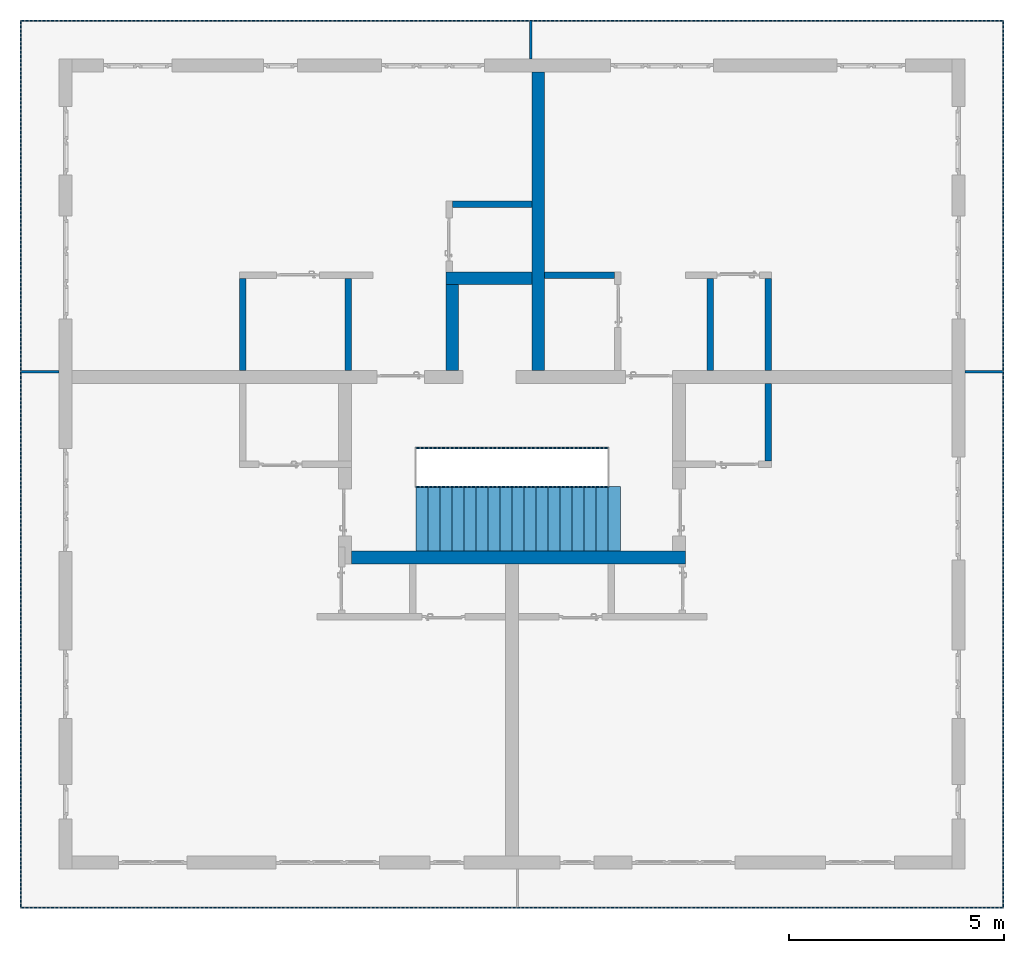
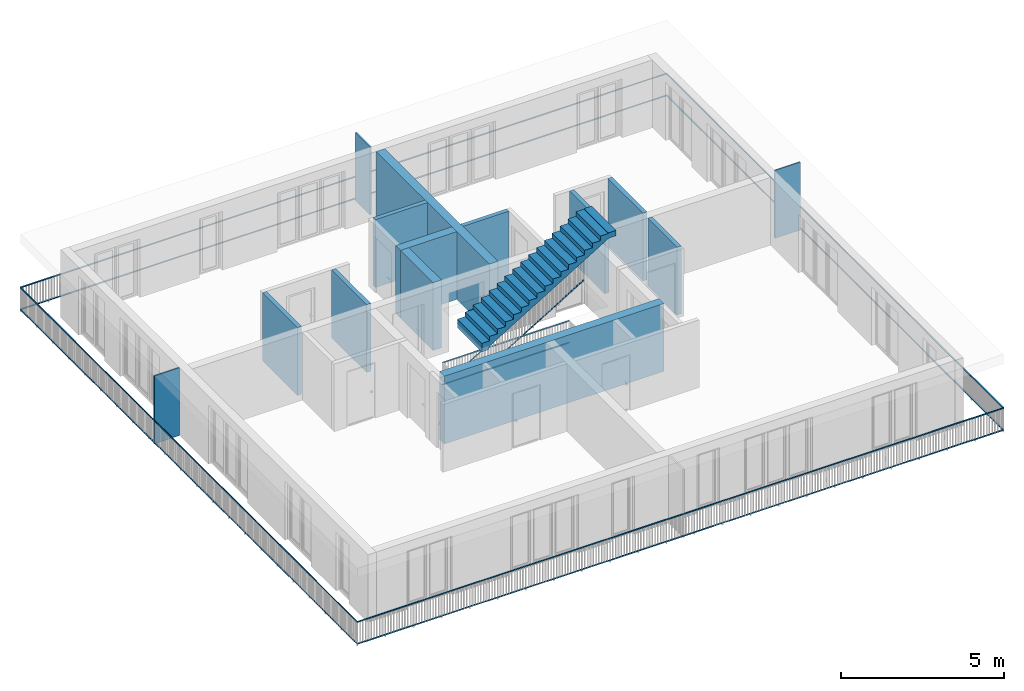
# One storey, part 24 of 48: 14 walls, 13 building element parts, 4 elements without a shape of their own.
"""IFC4 building model written with IfcOpenShell, lengths in metres."""

from ifc_helpers import new_model, entity, si_unit, converted_unit, derived_unit, direction, frame, origin_with_axes, place, context, subcontext, project, spatial, polygons, material, type_object, element, aggregate, save


model = new_model("IFC4")

# Units and contexts
model_context = context("Model", 3, precision=1e-05, world=origin_with_axes(), true_north=direction((0.0, 1.0)))
body_context = subcontext(model_context, "Body", "Model", "MODEL_VIEW")
ifc_project = project(units=[si_unit("LENGTHUNIT", "METRE"), si_unit("AREAUNIT", "SQUARE_METRE"), si_unit("VOLUMEUNIT", "CUBIC_METRE"), converted_unit("PLANEANGLEUNIT", "DEGREE", entity("IfcPlaneAngleMeasure", 0.0174532925199), si_unit("PLANEANGLEUNIT", "RADIAN"), dimensions=[0, 0, 0, 0, 0, 0, 0]), converted_unit("TIMEUNIT", "Year", entity("IfcTimeMeasure", 31556926.0), si_unit("TIMEUNIT", "SECOND"), dimensions=[0, 0, 1, 0, 0, 0, 0]), si_unit("MASSUNIT", "GRAM", prefix="KILO"), si_unit("THERMODYNAMICTEMPERATUREUNIT", "DEGREE_CELSIUS"), si_unit("LUMINOUSINTENSITYUNIT", "LUMEN"), si_unit("ENERGYUNIT", "JOULE", prefix="MEGA"), derived_unit("THERMALCONDUCTANCEUNIT", [(si_unit("POWERUNIT", "WATT"), 1), (si_unit("LENGTHUNIT", "METRE"), -1), (si_unit("THERMODYNAMICTEMPERATUREUNIT", "KELVIN"), -1)]), derived_unit("SPECIFICHEATCAPACITYUNIT", [(si_unit("ENERGYUNIT", "JOULE"), 1), (si_unit("MASSUNIT", "GRAM", prefix="KILO"), -1), (si_unit("THERMODYNAMICTEMPERATUREUNIT", "KELVIN"), -1)]), derived_unit("MASSDENSITYUNIT", [(si_unit("MASSUNIT", "GRAM", prefix="KILO"), 1), (si_unit("VOLUMEUNIT", "CUBIC_METRE"), -1)])], contexts=[model_context])

# Site, building, storey
site_placement = place(None, origin_with_axes())
site = spatial("IfcSite", under=ifc_project, at=site_placement, CompositionType="ELEMENT")
building_placement = place(site_placement, origin_with_axes())
building = spatial("IfcBuilding", under=site, at=building_placement, CompositionType="ELEMENT")
storey_placement = place(building_placement, frame((0.0, 0.0, 3.4), z_axis=(0.0, 0.0, 1.0), x_axis=(1.0, 0.0, 0.0)))
storey = spatial("IfcBuildingStorey", under=building, at=storey_placement, Name="1. Geschoss", CompositionType="ELEMENT", Elevation=3.4)

# Walls
ifc_material_1 = material()
wall_type_1 = type_object("IfcWallType", Name="300", PredefinedType="NOTDEFINED")
wall_1_placement = place(storey_placement, frame((2.8378006196, -2.52881223104, 0.0), z_axis=(0.0, 0.0, 1.0), x_axis=(-1.0, 0.0, 0.0)))
element("IfcWall", 1, at=wall_1_placement, inside=storey, type_object=wall_type_1, material=ifc_material_1, Name="Wand-001", PredefinedType="NOTDEFINED", context=body_context, shape_type="Tessellation", body=[
    polygons([(7.78, 0.0, 2.54), (6.28, 0.0, 2.54), (1.8, 0.0, 2.54), (0.0, 0.0, 2.54), (0.0, 0.0, 0.0), (7.78, 0.0, 0.0), (7.78, 0.3, 2.54), (0.0, 0.3, 2.54), (0.0, 0.3, 0.0), (7.78, 0.3, 0.0)], [[[1, 2, 3, 4, 5, 6]], [[4, 3, 2, 1, 7, 8]], [[5, 4, 8, 9]], [[5, 9, 10, 6]], [[10, 7, 1, 6]], [[8, 7, 10, 9]]], closed=True),
])
wall_2_placement = place(storey_placement, frame((-2.7421993804, 3.67118776896, 0.0), z_axis=(0.0, 0.0, 1.0), x_axis=(1.0, 0.0, 0.0)))
element("IfcWall", 2, at=wall_2_placement, inside=storey, type_object=wall_type_1, material=ifc_material_1, Name="Wand-001", PredefinedType="NOTDEFINED", context=body_context, shape_type="Tessellation", body=[
    polygons([(0.0, 0.3, 0.0), (0.0, 0.3, 2.54), (2.0, 0.3, 2.54), (2.0, 0.3, 0.0), (0.0, 0.0, 0.0), (0.0, 0.0, 2.54), (2.0, 0.0, 2.54), (2.0, 0.0, 0.0)], [[[1, 2, 3, 4]], [[5, 6, 2, 1]], [[6, 7, 3, 2]], [[4, 3, 7, 8]], [[5, 1, 4, 8]], [[8, 7, 6, 5]]], closed=True),
])
wall_3_placement = place(storey_placement, frame((-2.7421993804, 1.37118776896, 0.0), z_axis=(0.0, 0.0, 1.0), x_axis=(0.0, 1.0, 0.0)))
element("IfcWall", 3, at=wall_3_placement, inside=storey, type_object=wall_type_1, material=ifc_material_1, Name="Wand-001", PredefinedType="NOTDEFINED", context=body_context, shape_type="Tessellation", body=[
    polygons([(2.3, 0.0, 0.0), (2.3, 0.0, 2.54), (2.3, -0.3, 2.54), (2.3, -0.3, 0.0), (0.3, 0.0, 0.0), (0.3, 0.0, 2.54), (0.3, -0.3, 2.54), (0.3, -0.3, 0.0)], [[[1, 2, 3, 4]], [[5, 6, 2, 1]], [[6, 7, 3, 2]], [[4, 3, 7, 8]], [[5, 1, 4, 8]], [[8, 7, 6, 5]]], closed=True),
])
wall_4_placement = place(storey_placement, frame((-0.742199380397, 1.37118776896, 0.0), z_axis=(0.0, 0.0, 1.0), x_axis=(0.0, 1.0, 0.0)))
element("IfcWall", 4, at=wall_4_placement, inside=storey, type_object=wall_type_1, material=ifc_material_1, Name="Wand-001", PredefinedType="NOTDEFINED", context=body_context, shape_type="Tessellation", body=[
    polygons([(7.25, 0.0, 0.0), (7.25, 0.0, 2.54), (7.25, -0.3, 2.54), (7.25, -0.3, 0.0), (0.3, 0.0, 0.0), (0.3, 0.0, 2.54), (0.3, -0.3, 2.54), (0.3, -0.3, 0.0)], [[[1, 2, 3, 4]], [[5, 6, 2, 1]], [[6, 7, 3, 2]], [[4, 3, 7, 8]], [[8, 5, 1, 4]], [[8, 7, 6, 5]]], closed=True),
])
wall_type_2 = type_object("IfcWallType", Name="150", PredefinedType="NOTDEFINED")
wall_5_placement = place(storey_placement, frame((3.3378006196, 1.37118776896, 0.0), z_axis=(0.0, 0.0, 1.0), x_axis=(0.0, 1.0, 0.0)))
element("IfcWall", 5, at=wall_5_placement, inside=storey, type_object=wall_type_2, material=ifc_material_1, Name="Wand-002", PredefinedType="NOTDEFINED", context=body_context, shape_type="Tessellation", body=[
    polygons([(2.45, 0.0, 0.0), (2.45, 0.0, 2.54), (2.45, -0.15, 2.54), (2.45, -0.15, 0.0), (0.3, 0.0, 0.0), (0.3, 0.0, 2.54), (0.3, -0.15, 2.54), (0.3, -0.15, 0.0)], [[[1, 2, 3, 4]], [[5, 6, 2, 1]], [[6, 7, 3, 2]], [[4, 3, 7, 8]], [[5, 1, 4, 8]], [[8, 7, 6, 5]]], closed=True),
])
wall_6_placement = place(storey_placement, frame((-4.9421993804, 1.37118776896, 0.0), z_axis=(0.0, 0.0, 1.0), x_axis=(0.0, 1.0, 0.0)))
element("IfcWall", 6, at=wall_6_placement, inside=storey, type_object=wall_type_2, material=ifc_material_1, Name="Wand-002", PredefinedType="NOTDEFINED", context=body_context, shape_type="Tessellation", body=[
    polygons([(2.45, 0.15, 0.0), (2.45, 0.15, 2.54), (2.45, 0.0, 2.54), (2.45, 0.0, 0.0), (0.3, 0.15, 0.0), (0.3, 0.15, 2.54), (0.3, 0.0, 2.54), (0.3, 0.0, 0.0)], [[[1, 2, 3, 4]], [[5, 6, 2, 1]], [[6, 7, 3, 2]], [[4, 3, 7, 8]], [[5, 1, 4, 8]], [[8, 7, 6, 5]]], closed=True),
])
wall_7_placement = place(storey_placement, frame((-7.5421993804, 3.97118776896, 0.0), z_axis=(0.0, 0.0, 1.0), x_axis=(0.0, -1.0, 0.0)))
element("IfcWall", 7, at=wall_7_placement, inside=storey, type_object=wall_type_2, material=ifc_material_1, Name="Wand-003", PredefinedType="NOTDEFINED", context=body_context, shape_type="Tessellation", body=[
    polygons([(0.15, 0.0, 0.0), (0.15, 0.0, 2.54), (0.15, 0.15, 2.54), (0.15, 0.15, 0.0), (2.3, 0.0, 0.0), (2.3, 0.0, 2.54), (2.3, 0.15, 2.54), (2.3, 0.15, 0.0)], [[[1, 2, 3, 4]], [[5, 6, 2, 1]], [[6, 7, 3, 2]], [[4, 3, 7, 8]], [[1, 4, 8, 5]], [[8, 7, 6, 5]]], closed=True),
])
wall_8_placement = place(storey_placement, frame((1.3378006196, 3.97118776896, 0.0), z_axis=(0.0, 0.0, 1.0), x_axis=(-1.0, 0.0, 0.0)))
element("IfcWall", 8, at=wall_8_placement, inside=storey, type_object=wall_type_2, material=ifc_material_1, Name="Wand-002", PredefinedType="NOTDEFINED", context=body_context, shape_type="Tessellation", body=[
    polygons([(1.78, 0.0, 0.0), (1.78, 0.0, 2.54), (0.15, 0.0, 2.54), (0.15, 0.0, 0.0), (1.78, 0.15, 0.0), (1.78, 0.15, 2.54), (0.15, 0.15, 2.54), (0.15, 0.15, 0.0)], [[[1, 2, 3, 4]], [[5, 6, 2, 1]], [[6, 7, 3, 2]], [[4, 3, 7, 8]], [[8, 5, 1, 4]], [[8, 7, 6, 5]]], closed=True),
])
wall_9_placement = place(storey_placement, frame((-2.7421993804, 5.47118776896, 0.0), z_axis=(0.0, 0.0, 1.0), x_axis=(1.0, 0.0, 0.0)))
element("IfcWall", 9, at=wall_9_placement, inside=storey, type_object=wall_type_2, material=ifc_material_1, Name="Wand-002", PredefinedType="NOTDEFINED", context=body_context, shape_type="Tessellation", body=[
    polygons([(0.15, 0.15, 0.0), (0.15, 0.15, 2.54), (2.0, 0.15, 2.54), (2.0, 0.15, 0.0), (0.15, 0.0, 0.0), (0.15, 0.0, 2.54), (2.0, 0.0, 2.54), (2.0, 0.0, 0.0)], [[[1, 2, 3, 4]], [[5, 6, 2, 1]], [[6, 7, 3, 2]], [[4, 3, 7, 8]], [[1, 4, 8, 5]], [[8, 7, 6, 5]]], closed=True),
])
wall_10_placement = place(storey_placement, frame((4.6878006196, -0.428812231043, 0.0), z_axis=(0.0, 0.0, 1.0), x_axis=(0.0, 1.0, 0.0)))
element("IfcWall", 10, at=wall_10_placement, inside=storey, type_object=wall_type_2, material=ifc_material_1, Name="Wand-002", PredefinedType="NOTDEFINED", context=body_context, shape_type="Tessellation", body=[
    polygons([(1.8, 0.0, 0.0), (1.8, 0.0, 2.54), (1.8, -0.15, 2.54), (1.8, -0.15, 0.0), (0.0, 0.0, 0.0), (0.0, 0.0, 2.54), (0.0, -0.15, 2.54), (0.0, -0.15, 0.0)], [[[1, 2, 3, 4]], [[5, 6, 2, 1]], [[6, 7, 3, 2]], [[4, 3, 7, 8]], [[5, 1, 4, 8]], [[8, 7, 6, 5]]], closed=True),
])
wall_11_placement = place(storey_placement, frame((4.6878006196, 1.37118776896, 0.0), z_axis=(0.0, 0.0, 1.0), x_axis=(0.0, 1.0, 0.0)))
element("IfcWall", 11, at=wall_11_placement, inside=storey, type_object=wall_type_2, material=ifc_material_1, Name="Wand-002", PredefinedType="NOTDEFINED", context=body_context, shape_type="Tessellation", body=[
    polygons([(2.45, 0.0, 0.0), (2.45, 0.0, 2.54), (2.45, -0.15, 2.54), (2.45, -0.15, 0.0), (0.3, 0.0, 0.0), (0.3, 0.0, 2.54), (0.3, -0.15, 2.54), (0.3, -0.15, 0.0)], [[[1, 2, 3, 4]], [[5, 6, 2, 1]], [[6, 7, 3, 2]], [[4, 3, 7, 8]], [[1, 4, 8, 5]], [[8, 7, 6, 5]]], closed=True),
])
ifc_material_2 = material()
wall_type_3 = type_object("IfcWallType", Name="50", PredefinedType="NOTDEFINED")
wall_12_placement = place(storey_placement, frame((-0.742199380397, 9.82118776896, 0.0), z_axis=(0.0, 0.0, 1.0), x_axis=(0.0, -1.0, 0.0)))
element("IfcWall", 12, at=wall_12_placement, inside=storey, type_object=wall_type_3, material=ifc_material_2, Name="Wand-003", PredefinedType="NOTDEFINED", context=body_context, shape_type="Tessellation", body=[
    polygons([(0.0, -0.05, 2.54), (0.0, 0.0, 2.54), (0.0, 0.0, 0.0), (0.0, -0.05, 0.0), (0.9, 0.0, 2.54), (0.9, -0.05, 2.54), (0.9, 0.0, 0.0), (0.9, -0.05, 0.0)], [[[1, 2, 3, 4]], [[5, 2, 1, 6]], [[2, 5, 7, 3]], [[7, 8, 4, 3]], [[6, 1, 4, 8]], [[5, 6, 8, 7]]], closed=True),
])
wall_13_placement = place(storey_placement, frame((9.0378006196, 1.67118776896, 0.0), z_axis=(0.0, 0.0, 1.0), x_axis=(1.0, 0.0, 0.0)))
element("IfcWall", 13, at=wall_13_placement, inside=storey, type_object=wall_type_3, material=ifc_material_2, Name="Wand-003", PredefinedType="NOTDEFINED", context=body_context, shape_type="Tessellation", body=[
    polygons([(0.3, 0.0, 2.54), (1.2, 0.0, 2.54), (1.2, 0.0, 0.0), (0.3, 0.0, 0.0), (1.2, -0.05, 2.54), (0.3, -0.05, 2.54), (1.2, -0.05, 0.0), (0.3, -0.05, 0.0)], [[[1, 2, 3, 4]], [[5, 2, 1, 6]], [[2, 5, 7, 3]], [[4, 3, 7, 8]], [[6, 1, 4, 8]], [[5, 6, 8, 7]]], closed=True),
])
wall_14_placement = place(storey_placement, frame((-12.6421993804, 1.67118776896, 0.0), z_axis=(0.0, 0.0, 1.0), x_axis=(1.0, 0.0, 0.0)))
element("IfcWall", 14, at=wall_14_placement, inside=storey, type_object=wall_type_3, material=ifc_material_2, Name="Wand-003", PredefinedType="NOTDEFINED", context=body_context, shape_type="Tessellation", body=[
    polygons([(0.0, 0.0, 2.54), (0.9, 0.0, 2.54), (0.9, 0.0, 0.0), (0.0, 0.0, 0.0), (0.9, -0.05, 2.54), (0.0, -0.05, 2.54), (0.9, -0.05, 0.0), (0.0, -0.05, 0.0)], [[[1, 2, 3, 4]], [[5, 2, 1, 6]], [[2, 5, 7, 3]], [[3, 7, 8, 4]], [[6, 1, 4, 8]], [[5, 6, 8, 7]]], closed=True),
])

# Railing, building element parts
railing_type = type_object("IfcRailingType", PredefinedType="NOTDEFINED")
railing_1_placement = place(storey_placement, frame((10.2378006196, 9.82118776896, 0.0), z_axis=(0.0, 0.0, 1.0), x_axis=(1.0, 0.0, 0.0)))
railing_1 = element("IfcRailing", 15, at=railing_1_placement, inside=storey, type_object=railing_type, PredefinedType="NOTDEFINED")
ifc_material_3 = material()
building_element_part_1_placement = place(railing_1_placement, origin_with_axes())
building_element_part_1 = element("IfcBuildingElementPart", 16, at=building_element_part_1_placement, material=ifc_material_3, PredefinedType="NOTDEFINED", context=body_context, shape_type="Tessellation", body=[
    polygons([(0.0, 0.0125, 0.9), (0.0, 0.0125, 0.875), (-22.8925, 0.0125, 0.875), (-22.8925, 0.0125, 0.9), (0.0, -0.0125, 0.9), (0.0, -0.0125, 0.875), (-22.8675, -0.0125, 0.875), (-22.8675, -0.0125, 0.9)], [[[1, 2, 3, 4]], [[1, 5, 6, 2]], [[2, 6, 7, 3]], [[4, 3, 7, 8]], [[5, 1, 4, 8]], [[6, 5, 8, 7]]], closed=True),
])
building_element_part_2_placement = place(railing_1_placement, origin_with_axes())
building_element_part_2 = element("IfcBuildingElementPart", 17, at=building_element_part_2_placement, material=ifc_material_3, PredefinedType="NOTDEFINED", context=body_context, shape_type="Tessellation", body=[
    polygons([(0.0, 0.0125, 0.0825), (0.0, 0.0125, 0.0575), (-22.8925, 0.0125, 0.0575), (-22.8925, 0.0125, 0.0825), (0.0, -0.0125, 0.0825), (0.0, -0.0125, 0.0575), (-22.8675, -0.0125, 0.0575), (-22.8675, -0.0125, 0.0825)], [[[1, 2, 3, 4]], [[1, 5, 6, 2]], [[2, 6, 7, 3]], [[4, 3, 7, 8]], [[5, 1, 4, 8]], [[6, 5, 8, 7]]], closed=True),
])
building_element_part_3_placement = place(railing_1_placement, origin_with_axes())
building_element_part_3 = element("IfcBuildingElementPart", 18, at=building_element_part_3_placement, material=ifc_material_3, PredefinedType="NOTDEFINED", context=body_context, shape_type="Tessellation", body=[
    polygons([(-22.8925, 0.0125, 0.9), (-22.8925, 0.0125, 0.875), (-22.8925, -20.6625, 0.875), (-22.8925, -20.6625, 0.9), (-22.8675, -0.0125, 0.9), (-22.8675, -0.0125, 0.875), (-22.8675, -20.6375, 0.875), (-22.8675, -20.6375, 0.9)], [[[1, 2, 3, 4]], [[1, 5, 6, 2]], [[2, 6, 7, 3]], [[4, 3, 7, 8]], [[5, 1, 4, 8]], [[6, 5, 8, 7]]], closed=True),
])
building_element_part_4_placement = place(railing_1_placement, origin_with_axes())
building_element_part_4 = element("IfcBuildingElementPart", 19, at=building_element_part_4_placement, material=ifc_material_3, PredefinedType="NOTDEFINED", context=body_context, shape_type="Tessellation", body=[
    polygons([(-22.8925, 0.0125, 0.0825), (-22.8925, 0.0125, 0.0575), (-22.8925, -20.6625, 0.0575), (-22.8925, -20.6625, 0.0825), (-22.8675, -0.0125, 0.0825), (-22.8675, -0.0125, 0.0575), (-22.8675, -20.6375, 0.0575), (-22.8675, -20.6375, 0.0825)], [[[1, 2, 3, 4]], [[1, 5, 6, 2]], [[2, 6, 7, 3]], [[4, 3, 7, 8]], [[5, 1, 4, 8]], [[6, 5, 8, 7]]], closed=True),
])
building_element_part_5_placement = place(railing_1_placement, origin_with_axes())
building_element_part_5 = element("IfcBuildingElementPart", 20, at=building_element_part_5_placement, material=ifc_material_3, PredefinedType="NOTDEFINED", context=body_context, shape_type="Tessellation", body=[
    polygons([(-22.8925, -20.6625, 0.9), (-22.8925, -20.6625, 0.875), (0.0125, -20.6625, 0.875), (0.0125, -20.6625, 0.9), (-22.8675, -20.6375, 0.9), (-22.8675, -20.6375, 0.875), (-0.0125, -20.6375, 0.875), (-0.0125, -20.6375, 0.9)], [[[1, 2, 3, 4]], [[1, 5, 6, 2]], [[2, 6, 7, 3]], [[4, 3, 7, 8]], [[5, 1, 4, 8]], [[6, 5, 8, 7]]], closed=True),
])
building_element_part_6_placement = place(railing_1_placement, origin_with_axes())
building_element_part_6 = element("IfcBuildingElementPart", 21, at=building_element_part_6_placement, material=ifc_material_3, PredefinedType="NOTDEFINED", context=body_context, shape_type="Tessellation", body=[
    polygons([(-22.8925, -20.6625, 0.0825), (-22.8925, -20.6625, 0.0575), (0.0125, -20.6625, 0.0575), (0.0125, -20.6625, 0.0825), (-22.8675, -20.6375, 0.0825), (-22.8675, -20.6375, 0.0575), (-0.0125, -20.6375, 0.0575), (-0.0125, -20.6375, 0.0825)], [[[1, 2, 3, 4]], [[1, 5, 6, 2]], [[2, 6, 7, 3]], [[4, 3, 7, 8]], [[5, 1, 4, 8]], [[6, 5, 8, 7]]], closed=True),
])
building_element_part_7_placement = place(railing_1_placement, origin_with_axes())
building_element_part_7 = element("IfcBuildingElementPart", 22, at=building_element_part_7_placement, material=ifc_material_3, PredefinedType="NOTDEFINED", context=body_context, shape_type="Tessellation", body=[
    polygons([(0.0125, -20.6625, 0.9), (0.0125, -20.6625, 0.875), (0.0125, 0.0, 0.875), (0.0125, 0.0, 0.9), (-0.0125, -20.6375, 0.9), (-0.0125, -20.6375, 0.875), (-0.0125, 0.0, 0.875), (-0.0125, 0.0, 0.9)], [[[1, 2, 3, 4]], [[1, 5, 6, 2]], [[2, 6, 7, 3]], [[4, 3, 7, 8]], [[5, 1, 4, 8]], [[6, 5, 8, 7]]], closed=True),
])
building_element_part_8_placement = place(railing_1_placement, origin_with_axes())
building_element_part_8 = element("IfcBuildingElementPart", 23, at=building_element_part_8_placement, material=ifc_material_3, PredefinedType="NOTDEFINED", context=body_context, shape_type="Tessellation", body=[
    polygons([(0.0125, -20.6625, 0.0825), (0.0125, -20.6625, 0.0575), (0.0125, 0.0, 0.0575), (0.0125, 0.0, 0.0825), (-0.0125, -20.6375, 0.0825), (-0.0125, -20.6375, 0.0575), (-0.0125, 0.0, 0.0575), (-0.0125, 0.0, 0.0825)], [[[1, 2, 3, 4]], [[1, 5, 6, 2]], [[2, 6, 7, 3]], [[4, 3, 7, 8]], [[5, 1, 4, 8]], [[6, 5, 8, 7]]], closed=True),
])
aggregate(railing_1, [building_element_part_1, building_element_part_2, building_element_part_3, building_element_part_4, building_element_part_5, building_element_part_6, building_element_part_7, building_element_part_8])

# Space
space_placement = place(storey_placement, frame((-3.4421993804, -2.52881223104, 0.0), z_axis=(0.0, 0.0, 1.0), x_axis=(1.0, 0.0, 0.0)))
space = spatial("IfcSpace", under=storey, at=space_placement, CompositionType="ELEMENT", PredefinedType="INTERNAL")

# Railing, building element parts
railing_2_placement = place(space_placement, frame((0.0, 1.5, 0.17), z_axis=(0.0, 0.0, 1.0), x_axis=(1.0, 0.0, 0.0)))
railing_2 = element("IfcRailing", 24, at=railing_2_placement, inside=space, type_object=railing_type, PredefinedType="NOTDEFINED")
building_element_part_9_placement = place(railing_2_placement, origin_with_axes())
building_element_part_9 = element("IfcBuildingElementPart", 25, at=building_element_part_9_placement, material=ifc_material_3, PredefinedType="NOTDEFINED", context=body_context, shape_type="Tessellation", body=[
    polygons([(0.0, -0.0125, 0.9), (0.012974453356, -0.0125, 0.878630312119), (4.49297445336, -0.0125, 3.59863031212), (4.48, -0.0125, 3.62), (0.0, 0.0125, 0.9), (0.012974453356, 0.0125, 0.878630312119), (4.49297445336, 0.0125, 3.59863031212), (4.48, 0.0125, 3.62)], [[[1, 2, 3, 4]], [[1, 5, 6, 2]], [[2, 6, 7, 3]], [[4, 3, 7, 8]], [[5, 1, 4, 8]], [[6, 5, 8, 7]]], closed=True),
])
building_element_part_10_placement = place(railing_2_placement, origin_with_axes())
building_element_part_10 = element("IfcBuildingElementPart", 26, at=building_element_part_10_placement, material=ifc_material_3, PredefinedType="NOTDEFINED", context=body_context, shape_type="Tessellation", body=[
    polygons([(-0.00648722667802, -0.0125, 0.0806848439403), (0.00648722667802, -0.0125, 0.0593151560597), (4.48648722668, -0.0125, 2.77931515606), (4.47351277332, -0.0125, 2.80068484394), (-0.00648722667802, 0.0125, 0.0806848439403), (0.00648722667802, 0.0125, 0.0593151560597), (4.48648722668, 0.0125, 2.77931515606), (4.47351277332, 0.0125, 2.80068484394)], [[[1, 2, 3, 4]], [[1, 5, 6, 2]], [[2, 6, 7, 3]], [[4, 3, 7, 8]], [[5, 1, 4, 8]], [[6, 5, 8, 7]]], closed=True),
])
aggregate(railing_2, [building_element_part_9, building_element_part_10])

railing_3_placement = place(space_placement, frame((0.0, 1.5, 0.0), z_axis=(0.0, 0.0, 1.0), x_axis=(1.0, 0.0, 0.0)))
railing_3 = element("IfcRailing", 27, at=railing_3_placement, inside=space, type_object=railing_type, PredefinedType="NOTDEFINED")
building_element_part_11_placement = place(railing_3_placement, origin_with_axes())
building_element_part_11 = element("IfcBuildingElementPart", 28, at=building_element_part_11_placement, material=ifc_material_3, PredefinedType="NOTDEFINED", context=body_context, shape_type="Tessellation", body=[
    polygons([(0.0125, 0.8875, 0.9), (0.0125, 0.8875, 0.875), (4.4675, 0.8875, 0.875), (4.4675, 0.8875, 0.9), (-0.0125, 0.9125, 0.9), (-0.0125, 0.9125, 0.875), (4.4925, 0.9125, 0.875), (4.4925, 0.9125, 0.9)], [[[1, 2, 3, 4]], [[1, 5, 6, 2]], [[2, 6, 7, 3]], [[4, 3, 7, 8]], [[5, 1, 4, 8]], [[6, 5, 8, 7]]], closed=True),
])
building_element_part_12_placement = place(railing_3_placement, origin_with_axes())
building_element_part_12 = element("IfcBuildingElementPart", 29, at=building_element_part_12_placement, material=ifc_material_3, PredefinedType="NOTDEFINED", context=body_context, shape_type="Tessellation", body=[
    polygons([(0.0125, 0.8875, 0.0825), (0.0125, 0.8875, 0.0575), (4.4675, 0.8875, 0.0575), (4.4675, 0.8875, 0.0825), (-0.0125, 0.9125, 0.0825), (-0.0125, 0.9125, 0.0575), (4.4925, 0.9125, 0.0575), (4.4925, 0.9125, 0.0825)], [[[1, 2, 3, 4]], [[1, 5, 6, 2]], [[2, 6, 7, 3]], [[4, 3, 7, 8]], [[5, 1, 4, 8]], [[6, 5, 8, 7]]], closed=True),
])
aggregate(railing_3, [building_element_part_11, building_element_part_12])

# Stair, building element part
stair_type = type_object("IfcStairType", PredefinedType="NOTDEFINED")
stair_placement = place(space_placement, frame((0.0, 1.5, 2.89), z_axis=(0.0, 0.0, 1.0), x_axis=(1.0, 0.0, 0.0)))
stair = element("IfcStair", 30, at=stair_placement, inside=space, type_object=stair_type, Name="Treppe - 001", PredefinedType="NOTDEFINED")
building_element_part_13_placement = place(stair_placement, origin_with_axes())
building_element_part_13 = element("IfcBuildingElementPart", 31, at=building_element_part_13_placement, material=ifc_material_1, PredefinedType="NOTDEFINED", context=body_context, shape_type="Tessellation", body=[
    polygons([(4.76, 0.0, 2.74), (4.76, -1.5, 2.74), (4.76, -1.5, 2.69112016499), (4.76, 0.0, 2.69112016499), (4.48, 0.0, 2.74), (4.48, -1.5, 2.74), (4.51109619885, -1.5, 2.54), (4.76, -1.5, 2.54), (4.48, -1.5, 2.72), (4.2, -1.5, 2.72), (4.2, -1.5, 2.55), (3.92, -1.5, 2.55), (3.92, -1.5, 2.38), (3.64, -1.5, 2.38), (3.64, -1.5, 2.21), (3.36, -1.5, 2.21), (3.36, -1.5, 2.04), (3.08, -1.5, 2.04), (3.08, -1.5, 1.87), (2.8, -1.5, 1.87), (2.8, -1.5, 1.7), (2.52, -1.5, 1.7), (2.52, -1.5, 1.53), (2.24, -1.5, 1.53), (2.24, -1.5, 1.36), (1.96, -1.5, 1.36), (1.96, -1.5, 1.19), (1.68, -1.5, 1.19), (1.68, -1.5, 1.02), (1.4, -1.5, 1.02), (1.4, -1.5, 0.85), (1.12, -1.5, 0.85), (1.12, -1.5, 0.68), (0.84, -1.5, 0.68), (0.84, -1.5, 0.51), (0.56, -1.5, 0.51), (0.56, -1.5, 0.34), (0.28, -1.5, 0.34), (0.28, -1.5, 0.17), (0.0, -1.5, 0.17), (0.0, -1.5, -0.15), (0.25, -1.5, -0.15), (0.25, -1.5, -0.0470941207291), (0.28, -1.5, -0.0288798350148), (0.373333333333, -1.5, 0.0277868316519), (0.466666666667, -1.5, 0.0844534983185), (0.56, -1.5, 0.141120164985), (0.653333333333, -1.5, 0.197786831652), (0.746666666667, -1.5, 0.254453498319), (0.84, -1.5, 0.311120164985), (0.933333333333, -1.5, 0.367786831652), (1.02666666667, -1.5, 0.424453498319), (1.12, -1.5, 0.481120164985), (1.21333333333, -1.5, 0.537786831652), (1.30666666667, -1.5, 0.594453498319), (1.4, -1.5, 0.651120164985), (1.49333333333, -1.5, 0.707786831652), (1.58666666667, -1.5, 0.764453498319), (1.68, -1.5, 0.821120164985), (1.77333333333, -1.5, 0.877786831652), (1.86666666667, -1.5, 0.934453498319), (1.96, -1.5, 0.991120164985), (2.05333333333, -1.5, 1.04778683165), (2.14666666667, -1.5, 1.10445349832), (2.24, -1.5, 1.16112016499), (2.33333333333, -1.5, 1.21778683165), (2.42666666667, -1.5, 1.27445349832), (2.52, -1.5, 1.33112016499), (2.61333333333, -1.5, 1.38778683165), (2.70666666667, -1.5, 1.44445349832), (2.8, -1.5, 1.50112016499), (2.89333333333, -1.5, 1.55778683165), (2.98666666667, -1.5, 1.61445349832), (3.08, -1.5, 1.67112016499), (3.17333333333, -1.5, 1.72778683165), (3.26666666667, -1.5, 1.78445349832), (3.36, -1.5, 1.84112016499), (3.45333333333, -1.5, 1.89778683165), (3.54666666667, -1.5, 1.95445349832), (3.64, -1.5, 2.01112016499), (3.73333333333, -1.5, 2.06778683165), (3.82666666667, -1.5, 2.12445349832), (3.92, -1.5, 2.18112016499), (4.01333333333, -1.5, 2.23778683165), (4.10666666667, -1.5, 2.29445349832), (4.2, -1.5, 2.35112016499), (4.29333333333, -1.5, 2.40778683165), (4.38666666667, -1.5, 2.46445349832), (4.48, -1.5, 2.52112016499), (4.76, 0.0, 2.54), (4.51109619885, 0.0, 2.54), (4.48, 0.0, 2.52112016499), (4.38666666667, 0.0, 2.46445349832), (4.29333333333, 0.0, 2.40778683165), (4.2, 0.0, 2.35112016499), (4.10666666667, 0.0, 2.29445349832), (4.01333333333, 0.0, 2.23778683165), (3.92, 0.0, 2.18112016499), (3.82666666667, 0.0, 2.12445349832), (3.73333333333, 0.0, 2.06778683165), (3.64, 0.0, 2.01112016499), (3.54666666667, 0.0, 1.95445349832), (3.45333333333, 0.0, 1.89778683165), (3.36, 0.0, 1.84112016499), (3.26666666667, 0.0, 1.78445349832), (3.17333333333, 0.0, 1.72778683165), (3.08, 0.0, 1.67112016499), (2.98666666667, 0.0, 1.61445349832), (2.89333333333, 0.0, 1.55778683165), (2.8, 0.0, 1.50112016499), (2.70666666667, 0.0, 1.44445349832), (2.61333333333, 0.0, 1.38778683165), (2.52, 0.0, 1.33112016499), (2.42666666667, 0.0, 1.27445349832), (2.33333333333, 0.0, 1.21778683165), (2.24, 0.0, 1.16112016499), (2.14666666667, 0.0, 1.10445349832), (2.05333333333, 0.0, 1.04778683165), (1.96, 0.0, 0.991120164985), (1.86666666667, 0.0, 0.934453498319), (1.77333333333, 0.0, 0.877786831652), (1.68, 0.0, 0.821120164985), (1.58666666667, 0.0, 0.764453498319), (1.49333333333, 0.0, 0.707786831652), (1.4, 0.0, 0.651120164985), (1.30666666667, 0.0, 0.594453498319), (1.21333333333, 0.0, 0.537786831652), (1.12, 0.0, 0.481120164985), (1.02666666667, 0.0, 0.424453498319), (0.933333333333, 0.0, 0.367786831652), (0.84, 0.0, 0.311120164985), (0.746666666667, 0.0, 0.254453498319), (0.653333333333, 0.0, 0.197786831652), (0.56, 0.0, 0.141120164985), (0.466666666667, 0.0, 0.0844534983185), (0.373333333333, 0.0, 0.0277868316519), (0.28, 0.0, -0.0288798350148), (0.25, 0.0, -0.0470941207291), (0.25, 0.0, -0.15), (0.0, 0.0, -0.15), (0.0, 0.0, 0.17), (0.28, 0.0, 0.17), (0.28, 0.0, 0.34), (0.56, 0.0, 0.34), (0.56, 0.0, 0.51), (0.84, 0.0, 0.51), (0.84, 0.0, 0.68), (1.12, 0.0, 0.68), (1.12, 0.0, 0.85), (1.4, 0.0, 0.85), (1.4, 0.0, 1.02), (1.68, 0.0, 1.02), (1.68, 0.0, 1.19), (1.96, 0.0, 1.19), (1.96, 0.0, 1.36), (2.24, 0.0, 1.36), (2.24, 0.0, 1.53), (2.52, 0.0, 1.53), (2.52, 0.0, 1.7), (2.8, 0.0, 1.7), (2.8, 0.0, 1.87), (3.08, 0.0, 1.87), (3.08, 0.0, 2.04), (3.36, 0.0, 2.04), (3.36, 0.0, 2.21), (3.64, 0.0, 2.21), (3.64, 0.0, 2.38), (3.92, 0.0, 2.38), (3.92, 0.0, 2.55), (4.2, 0.0, 2.55), (4.2, 0.0, 2.72), (4.48, 0.0, 2.72)], [[[1, 2, 3, 4]], [[2, 1, 5, 6]], [[7, 8, 3, 2, 6, 9, 10, 11, 12, 13, 14, 15, 16, 17, 18, 19, 20, 21, 22, 23, 24, 25, 26, 27, 28, 29, 30, 31, 32, 33, 34, 35, 36, 37, 38, 39, 40, 41, 42, 43, 44, 45, 46, 47, 48, 49, 50, 51, 52, 53, 54, 55, 56, 57, 58, 59, 60, 61, 62, 63, 64, 65, 66, 67, 68, 69, 70, 71, 72, 73, 74, 75, 76, 77, 78, 79, 80, 81, 82, 83, 84, 85, 86, 87, 88, 89]], [[8, 90, 4, 3]], [[5, 1, 4, 90, 91, 92, 93, 94, 95, 96, 97, 98, 99, 100, 101, 102, 103, 104, 105, 106, 107, 108, 109, 110, 111, 112, 113, 114, 115, 116, 117, 118, 119, 120, 121, 122, 123, 124, 125, 126, 127, 128, 129, 130, 131, 132, 133, 134, 135, 136, 137, 138, 139, 140, 141, 142, 143, 144, 145, 146, 147, 148, 149, 150, 151, 152, 153, 154, 155, 156, 157, 158, 159, 160, 161, 162, 163, 164, 165, 166, 167, 168, 169, 170, 171, 172]], [[5, 172, 9, 6]], [[90, 8, 7, 91]], [[10, 9, 172, 171]], [[171, 170, 11, 10]], [[12, 11, 170, 169]], [[169, 168, 13, 12]], [[14, 13, 168, 167]], [[167, 166, 15, 14]], [[16, 15, 166, 165]], [[165, 164, 17, 16]], [[18, 17, 164, 163]], [[163, 162, 19, 18]], [[20, 19, 162, 161]], [[161, 160, 21, 20]], [[22, 21, 160, 159]], [[159, 158, 23, 22]], [[24, 23, 158, 157]], [[157, 156, 25, 24]], [[26, 25, 156, 155]], [[155, 154, 27, 26]], [[28, 27, 154, 153]], [[153, 152, 29, 28]], [[30, 29, 152, 151]], [[151, 150, 31, 30]], [[32, 31, 150, 149]], [[149, 148, 33, 32]], [[34, 33, 148, 147]], [[147, 146, 35, 34]], [[36, 35, 146, 145]], [[145, 144, 37, 36]], [[38, 37, 144, 143]], [[143, 142, 39, 38]], [[40, 39, 142, 141]], [[140, 41, 40, 141]], [[41, 140, 139, 42]], [[43, 42, 139, 138]], [[138, 137, 44, 43]], [[137, 136, 45, 44]], [[136, 135, 46, 45]], [[135, 134, 47, 46]], [[134, 133, 48, 47]], [[133, 132, 49, 48]], [[132, 131, 50, 49]], [[131, 130, 51, 50]], [[130, 129, 52, 51]], [[129, 128, 53, 52]], [[128, 127, 54, 53]], [[127, 126, 55, 54]], [[126, 125, 56, 55]], [[125, 124, 57, 56]], [[124, 123, 58, 57]], [[123, 122, 59, 58]], [[122, 121, 60, 59]], [[121, 120, 61, 60]], [[120, 119, 62, 61]], [[119, 118, 63, 62]], [[118, 117, 64, 63]], [[117, 116, 65, 64]], [[116, 115, 66, 65]], [[115, 114, 67, 66]], [[114, 113, 68, 67]], [[113, 112, 69, 68]], [[112, 111, 70, 69]], [[111, 110, 71, 70]], [[110, 109, 72, 71]], [[109, 108, 73, 72]], [[108, 107, 74, 73]], [[107, 106, 75, 74]], [[106, 105, 76, 75]], [[105, 104, 77, 76]], [[104, 103, 78, 77]], [[103, 102, 79, 78]], [[102, 101, 80, 79]], [[101, 100, 81, 80]], [[100, 99, 82, 81]], [[99, 98, 83, 82]], [[98, 97, 84, 83]], [[97, 96, 85, 84]], [[96, 95, 86, 85]], [[95, 94, 87, 86]], [[94, 93, 88, 87]], [[93, 92, 89, 88]], [[89, 92, 91, 7]]], closed=True),
])
aggregate(stair, [building_element_part_13])

save(model, "model.ifc")
